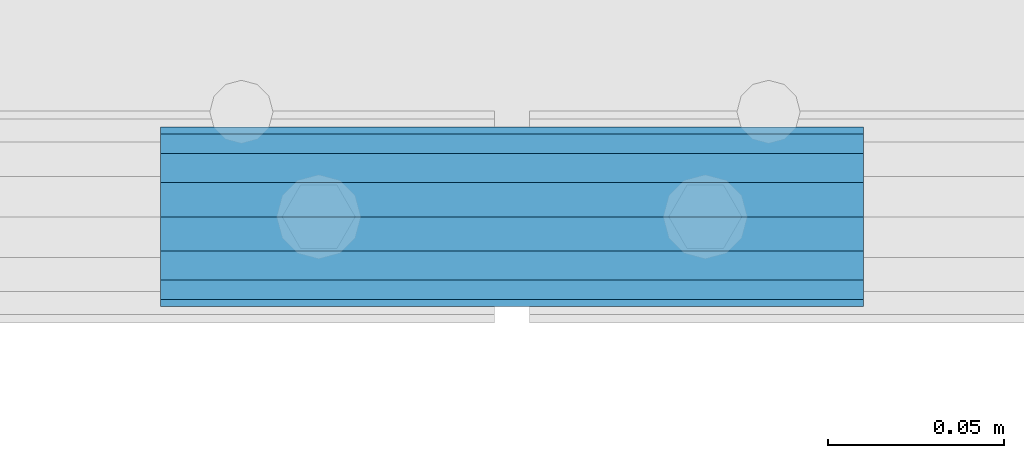
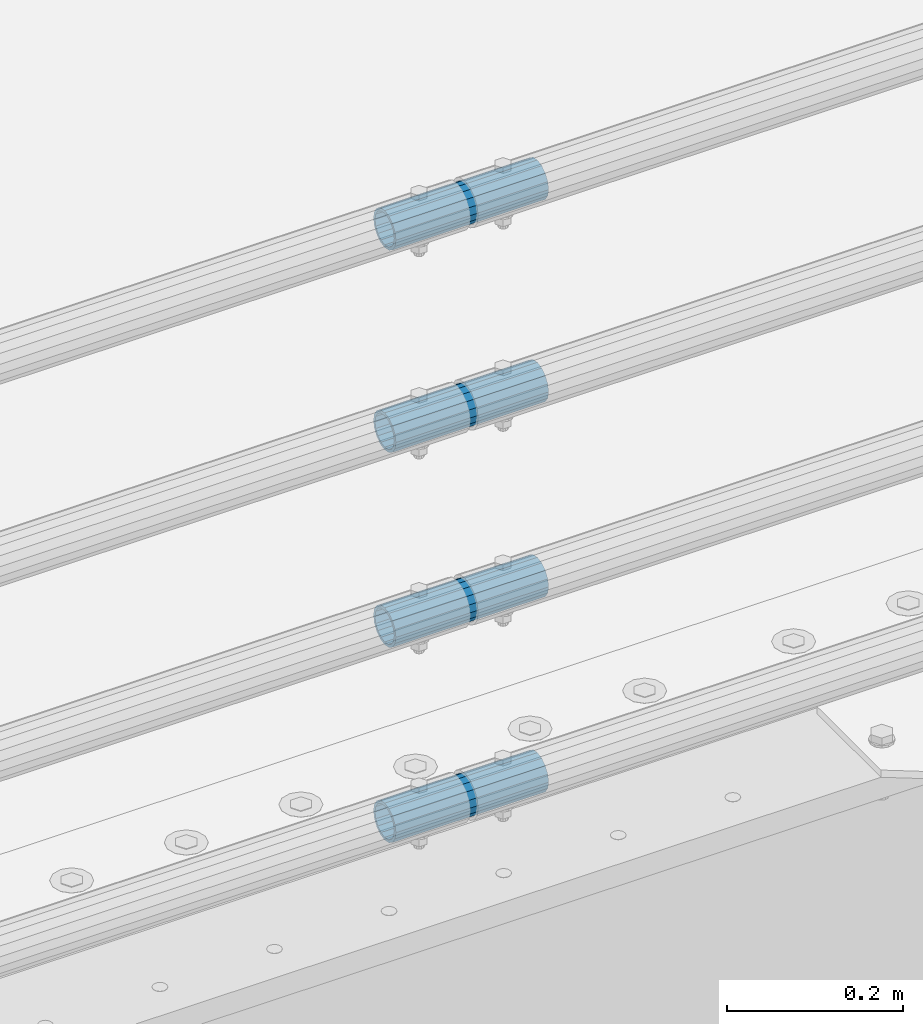
# One storey, part 143 of 257: 4 beams.
"""IFC2X3 building model written with IfcOpenShell, lengths in millimetres."""

from ifc_helpers import new_model, si_unit, frame, origin_with_axes, place, context, subcontext, project, spatial, faceted_brep, material, type_object, element, save


model = new_model("IFC2X3")

# Units and contexts
model_context = context("Model", 3, precision=1e-05, world=origin_with_axes())
body_context = subcontext(model_context, "Body", "Model", "MODEL_VIEW")
ifc_project = project(units=[si_unit("LENGTHUNIT", "METRE", prefix="MILLI"), si_unit("AREAUNIT", "SQUARE_METRE"), si_unit("VOLUMEUNIT", "CUBIC_METRE"), si_unit("MASSUNIT", "GRAM", prefix="KILO"), si_unit("TIMEUNIT", "SECOND"), si_unit("PLANEANGLEUNIT", "RADIAN"), si_unit("SOLIDANGLEUNIT", "STERADIAN"), si_unit("THERMODYNAMICTEMPERATUREUNIT", "DEGREE_CELSIUS"), si_unit("LUMINOUSINTENSITYUNIT", "LUMEN")], contexts=[model_context])

# Site, building, storey
site_placement = place(None, origin_with_axes())
site = spatial("IfcSite", under=ifc_project, at=site_placement, CompositionType="ELEMENT")
building_placement = place(site_placement, origin_with_axes())
building = spatial("IfcBuilding", under=site, at=building_placement, Name="Standard", CompositionType="ELEMENT")
storey_placement = place(building_placement, origin_with_axes())
storey = spatial("IfcBuildingStorey", under=building, at=storey_placement, Name="Undefined", CompositionType="ELEMENT", Elevation=0.0)

# Beams
ifc_material = material()
beam_type = type_object("IfcBeamType", PredefinedType="NOTDEFINED")
beam_1_placement = place(storey_placement, frame((56476.9975029999, -129.849999999603, 149.849999999725), z_axis=(0.0, 0.0, 1.0), x_axis=(1.0, 0.0, 0.0)))
element("IfcBeam", 1, at=beam_1_placement, inside=storey, type_object=beam_type, material=ifc_material, context=body_context, shape_type="Brep", body=[
    faceted_brep([(0.0, -21.8999999999996, 0.0), (0.0, -20.232961761998, 8.38076716879547), (200.0, -20.232961761998, 8.38076716879547), (200.0, -21.8999999999996, 0.0), (0.0, -15.4856385079856, 15.4856385079854), (200.0, -15.4856385079856, 15.4856385079854), (0.0, -8.3807671687955, 20.2329617619972), (200.0, -8.3807671687955, 20.2329617619972), (0.0, 0.0, 21.9), (200.0, 0.0, 21.9), (0.0, 8.3807671687955, 20.2329617619972), (200.0, 8.3807671687955, 20.2329617619972), (0.0, 15.4856385079856, 15.4856385079854), (200.0, 15.4856385079856, 15.4856385079854), (0.0, 20.232961761998, 8.38076716879547), (200.0, 20.232961761998, 8.38076716879547), (0.0, 21.8999999999996, 0.0), (200.0, 21.8999999999996, 0.0), (0.0, 20.232961761998, -8.38076716879547), (200.0, 20.232961761998, -8.38076716879547), (0.0, 15.4856385079856, -15.4856385079854), (200.0, 15.4856385079856, -15.4856385079854), (0.0, 8.3807671687955, -20.2329617619972), (200.0, 8.3807671687955, -20.2329617619972), (0.0, 0.0, -21.9), (200.0, 0.0, -21.9), (0.0, -8.3807671687955, -20.2329617619972), (200.0, -8.3807671687955, -20.2329617619972), (0.0, -15.4856385079856, -15.4856385079854), (200.0, -15.4856385079856, -15.4856385079854), (0.0, -20.232961761998, -8.38076716879547), (200.0, -20.232961761998, -8.38076716879547), (0.0, -25.5, 0.0), (0.0, -23.5589280790373, -9.7584275253098), (200.0, -23.5589280790373, -9.7584275253098), (200.0, -25.5, 0.0), (0.0, -18.0312229202573, -18.031222920257), (200.0, -18.0312229202573, -18.031222920257), (0.0, -9.75842752531025, -23.5589280790378), (200.0, -9.75842752531025, -23.5589280790378), (0.0, 0.0, -25.5), (200.0, 0.0, -25.5), (0.0, 9.75842752531025, -23.5589280790378), (200.0, 9.75842752531025, -23.5589280790378), (0.0, 18.0312229202573, -18.031222920257), (200.0, 18.0312229202573, -18.031222920257), (0.0, 23.5589280790373, -9.7584275253098), (200.0, 23.5589280790373, -9.7584275253098), (0.0, 25.5, 0.0), (200.0, 25.5, 0.0), (0.0, 23.5589280790373, 9.7584275253098), (200.0, 23.5589280790373, 9.7584275253098), (0.0, 18.0312229202573, 18.031222920257), (200.0, 18.0312229202573, 18.031222920257), (0.0, 9.75842752531025, 23.5589280790378), (200.0, 9.75842752531025, 23.5589280790378), (0.0, 0.0, 25.5), (200.0, 0.0, 25.5), (0.0, -9.75842752531025, 23.5589280790378), (200.0, -9.75842752531025, 23.5589280790378), (0.0, -18.0312229202573, 18.031222920257), (200.0, -18.0312229202573, 18.031222920257), (0.0, -23.5589280790373, 9.7584275253098), (200.0, -23.5589280790373, 9.7584275253098)], [[[0, 1, 2, 3]], [[1, 4, 5, 2]], [[4, 6, 7, 5]], [[6, 8, 9, 7]], [[8, 10, 11, 9]], [[10, 12, 13, 11]], [[12, 14, 15, 13]], [[14, 16, 17, 15]], [[16, 18, 19, 17]], [[18, 20, 21, 19]], [[20, 22, 23, 21]], [[22, 24, 25, 23]], [[24, 26, 27, 25]], [[26, 28, 29, 27]], [[28, 30, 31, 29]], [[30, 0, 3, 31]], [[32, 33, 34, 35]], [[33, 36, 37, 34]], [[36, 38, 39, 37]], [[38, 40, 41, 39]], [[40, 42, 43, 41]], [[42, 44, 45, 43]], [[44, 46, 47, 45]], [[46, 48, 49, 47]], [[48, 50, 51, 49]], [[50, 52, 53, 51]], [[52, 54, 55, 53]], [[54, 56, 57, 55]], [[56, 58, 59, 57]], [[58, 60, 61, 59]], [[60, 62, 63, 61]], [[62, 32, 35, 63]], [[37, 39, 41, 43, 45, 47, 49, 51, 53, 55, 57, 59, 61, 63, 35, 34], [5, 7, 9, 11, 13, 15, 17, 19, 21, 23, 25, 27, 29, 31, 3, 2]], [[62, 60, 58, 56, 54, 52, 50, 48, 46, 44, 42, 40, 38, 36, 33, 32], [30, 28, 26, 24, 22, 20, 18, 16, 14, 12, 10, 8, 6, 4, 1, 0]]]),
])
beam_2_placement = place(storey_placement, frame((56476.9975029999, -129.849999999603, 420.149999999724), z_axis=(0.0, 0.0, 1.0), x_axis=(1.0, 0.0, 0.0)))
element("IfcBeam", 2, at=beam_2_placement, inside=storey, type_object=beam_type, material=ifc_material, context=body_context, shape_type="Brep", body=[
    faceted_brep([(0.0, -21.8999999999996, 0.0), (0.0, -20.232961761998, 8.38076716879547), (200.0, -20.232961761998, 8.38076716879547), (200.0, -21.8999999999996, 0.0), (0.0, -15.4856385079856, 15.4856385079854), (200.0, -15.4856385079856, 15.4856385079854), (0.0, -8.3807671687955, 20.2329617619972), (200.0, -8.3807671687955, 20.2329617619972), (0.0, 0.0, 21.9), (200.0, 0.0, 21.9), (0.0, 8.3807671687955, 20.2329617619972), (200.0, 8.3807671687955, 20.2329617619972), (0.0, 15.4856385079856, 15.4856385079854), (200.0, 15.4856385079856, 15.4856385079854), (0.0, 20.232961761998, 8.38076716879547), (200.0, 20.232961761998, 8.38076716879547), (0.0, 21.8999999999996, 0.0), (200.0, 21.8999999999996, 0.0), (0.0, 20.232961761998, -8.38076716879547), (200.0, 20.232961761998, -8.38076716879547), (0.0, 15.4856385079856, -15.4856385079854), (200.0, 15.4856385079856, -15.4856385079854), (0.0, 8.3807671687955, -20.2329617619972), (200.0, 8.3807671687955, -20.2329617619972), (0.0, 0.0, -21.9), (200.0, 0.0, -21.9), (0.0, -8.3807671687955, -20.2329617619972), (200.0, -8.3807671687955, -20.2329617619972), (0.0, -15.4856385079856, -15.4856385079854), (200.0, -15.4856385079856, -15.4856385079854), (0.0, -20.232961761998, -8.38076716879547), (200.0, -20.232961761998, -8.38076716879547), (0.0, -25.5, 0.0), (0.0, -23.5589280790373, -9.7584275253098), (200.0, -23.5589280790373, -9.7584275253098), (200.0, -25.5, 0.0), (0.0, -18.0312229202573, -18.031222920257), (200.0, -18.0312229202573, -18.031222920257), (0.0, -9.75842752531025, -23.5589280790378), (200.0, -9.75842752531025, -23.5589280790378), (0.0, 0.0, -25.5), (200.0, 0.0, -25.5), (0.0, 9.75842752531025, -23.5589280790378), (200.0, 9.75842752531025, -23.5589280790378), (0.0, 18.0312229202573, -18.031222920257), (200.0, 18.0312229202573, -18.031222920257), (0.0, 23.5589280790373, -9.7584275253098), (200.0, 23.5589280790373, -9.7584275253098), (0.0, 25.5, 0.0), (200.0, 25.5, 0.0), (0.0, 23.5589280790373, 9.7584275253098), (200.0, 23.5589280790373, 9.7584275253098), (0.0, 18.0312229202573, 18.031222920257), (200.0, 18.0312229202573, 18.031222920257), (0.0, 9.75842752531025, 23.5589280790378), (200.0, 9.75842752531025, 23.5589280790378), (0.0, 0.0, 25.5), (200.0, 0.0, 25.5), (0.0, -9.75842752531025, 23.5589280790378), (200.0, -9.75842752531025, 23.5589280790378), (0.0, -18.0312229202573, 18.031222920257), (200.0, -18.0312229202573, 18.031222920257), (0.0, -23.5589280790373, 9.7584275253098), (200.0, -23.5589280790373, 9.7584275253098)], [[[0, 1, 2, 3]], [[1, 4, 5, 2]], [[4, 6, 7, 5]], [[6, 8, 9, 7]], [[8, 10, 11, 9]], [[10, 12, 13, 11]], [[12, 14, 15, 13]], [[14, 16, 17, 15]], [[16, 18, 19, 17]], [[18, 20, 21, 19]], [[20, 22, 23, 21]], [[22, 24, 25, 23]], [[24, 26, 27, 25]], [[26, 28, 29, 27]], [[28, 30, 31, 29]], [[30, 0, 3, 31]], [[32, 33, 34, 35]], [[33, 36, 37, 34]], [[36, 38, 39, 37]], [[38, 40, 41, 39]], [[40, 42, 43, 41]], [[42, 44, 45, 43]], [[44, 46, 47, 45]], [[46, 48, 49, 47]], [[48, 50, 51, 49]], [[50, 52, 53, 51]], [[52, 54, 55, 53]], [[54, 56, 57, 55]], [[56, 58, 59, 57]], [[58, 60, 61, 59]], [[60, 62, 63, 61]], [[62, 32, 35, 63]], [[37, 39, 41, 43, 45, 47, 49, 51, 53, 55, 57, 59, 61, 63, 35, 34], [5, 7, 9, 11, 13, 15, 17, 19, 21, 23, 25, 27, 29, 31, 3, 2]], [[62, 60, 58, 56, 54, 52, 50, 48, 46, 44, 42, 40, 38, 36, 33, 32], [30, 28, 26, 24, 22, 20, 18, 16, 14, 12, 10, 8, 6, 4, 1, 0]]]),
])
beam_3_placement = place(storey_placement, frame((56476.9975029999, -129.849999999603, 969.849999999725), z_axis=(0.0, 0.0, 1.0), x_axis=(1.0, 0.0, 0.0)))
element("IfcBeam", 3, at=beam_3_placement, inside=storey, type_object=beam_type, material=ifc_material, context=body_context, shape_type="Brep", body=[
    faceted_brep([(0.0, -21.8999999999996, 0.0), (0.0, -20.232961761998, 8.38076716879547), (200.0, -20.232961761998, 8.38076716879547), (200.0, -21.8999999999996, 0.0), (0.0, -15.4856385079856, 15.4856385079854), (200.0, -15.4856385079856, 15.4856385079854), (0.0, -8.3807671687955, 20.2329617619972), (200.0, -8.3807671687955, 20.2329617619972), (0.0, 0.0, 21.9), (200.0, 0.0, 21.9), (0.0, 8.3807671687955, 20.2329617619972), (200.0, 8.3807671687955, 20.2329617619972), (0.0, 15.4856385079856, 15.4856385079854), (200.0, 15.4856385079856, 15.4856385079854), (0.0, 20.232961761998, 8.38076716879547), (200.0, 20.232961761998, 8.38076716879547), (0.0, 21.8999999999996, 0.0), (200.0, 21.8999999999996, 0.0), (0.0, 20.232961761998, -8.38076716879547), (200.0, 20.232961761998, -8.38076716879547), (0.0, 15.4856385079856, -15.4856385079854), (200.0, 15.4856385079856, -15.4856385079854), (0.0, 8.3807671687955, -20.2329617619972), (200.0, 8.3807671687955, -20.2329617619972), (0.0, 0.0, -21.9), (200.0, 0.0, -21.9), (0.0, -8.3807671687955, -20.2329617619972), (200.0, -8.3807671687955, -20.2329617619972), (0.0, -15.4856385079856, -15.4856385079854), (200.0, -15.4856385079856, -15.4856385079854), (0.0, -20.232961761998, -8.38076716879547), (200.0, -20.232961761998, -8.38076716879547), (0.0, -25.5, 0.0), (0.0, -23.5589280790373, -9.7584275253098), (200.0, -23.5589280790373, -9.7584275253098), (200.0, -25.5, 0.0), (0.0, -18.0312229202573, -18.031222920257), (200.0, -18.0312229202573, -18.031222920257), (0.0, -9.75842752531025, -23.5589280790378), (200.0, -9.75842752531025, -23.5589280790378), (0.0, 0.0, -25.5), (200.0, 0.0, -25.5), (0.0, 9.75842752531025, -23.5589280790378), (200.0, 9.75842752531025, -23.5589280790378), (0.0, 18.0312229202573, -18.031222920257), (200.0, 18.0312229202573, -18.031222920257), (0.0, 23.5589280790373, -9.7584275253098), (200.0, 23.5589280790373, -9.7584275253098), (0.0, 25.5, 0.0), (200.0, 25.5, 0.0), (0.0, 23.5589280790373, 9.7584275253098), (200.0, 23.5589280790373, 9.7584275253098), (0.0, 18.0312229202573, 18.031222920257), (200.0, 18.0312229202573, 18.031222920257), (0.0, 9.75842752531025, 23.5589280790378), (200.0, 9.75842752531025, 23.5589280790378), (0.0, 0.0, 25.5), (200.0, 0.0, 25.5), (0.0, -9.75842752531025, 23.5589280790378), (200.0, -9.75842752531025, 23.5589280790378), (0.0, -18.0312229202573, 18.031222920257), (200.0, -18.0312229202573, 18.031222920257), (0.0, -23.5589280790373, 9.7584275253098), (200.0, -23.5589280790373, 9.7584275253098)], [[[0, 1, 2, 3]], [[1, 4, 5, 2]], [[4, 6, 7, 5]], [[6, 8, 9, 7]], [[8, 10, 11, 9]], [[10, 12, 13, 11]], [[12, 14, 15, 13]], [[14, 16, 17, 15]], [[16, 18, 19, 17]], [[18, 20, 21, 19]], [[20, 22, 23, 21]], [[22, 24, 25, 23]], [[24, 26, 27, 25]], [[26, 28, 29, 27]], [[28, 30, 31, 29]], [[30, 0, 3, 31]], [[32, 33, 34, 35]], [[33, 36, 37, 34]], [[36, 38, 39, 37]], [[38, 40, 41, 39]], [[40, 42, 43, 41]], [[42, 44, 45, 43]], [[44, 46, 47, 45]], [[46, 48, 49, 47]], [[48, 50, 51, 49]], [[50, 52, 53, 51]], [[52, 54, 55, 53]], [[54, 56, 57, 55]], [[56, 58, 59, 57]], [[58, 60, 61, 59]], [[60, 62, 63, 61]], [[62, 32, 35, 63]], [[37, 39, 41, 43, 45, 47, 49, 51, 53, 55, 57, 59, 61, 63, 35, 34], [5, 7, 9, 11, 13, 15, 17, 19, 21, 23, 25, 27, 29, 31, 3, 2]], [[62, 60, 58, 56, 54, 52, 50, 48, 46, 44, 42, 40, 38, 36, 33, 32], [30, 28, 26, 24, 22, 20, 18, 16, 14, 12, 10, 8, 6, 4, 1, 0]]]),
])
beam_4_placement = place(storey_placement, frame((56476.9975029999, -129.849999999603, 689.849999999725), z_axis=(0.0, 0.0, 1.0), x_axis=(1.0, 0.0, 0.0)))
element("IfcBeam", 4, at=beam_4_placement, inside=storey, type_object=beam_type, material=ifc_material, context=body_context, shape_type="Brep", body=[
    faceted_brep([(0.0, -21.8999999999996, 0.0), (0.0, -20.232961761998, 8.38076716879547), (200.0, -20.232961761998, 8.38076716879547), (200.0, -21.8999999999996, 0.0), (0.0, -15.4856385079856, 15.4856385079854), (200.0, -15.4856385079856, 15.4856385079854), (0.0, -8.3807671687955, 20.2329617619972), (200.0, -8.3807671687955, 20.2329617619972), (0.0, 0.0, 21.9), (200.0, 0.0, 21.9), (0.0, 8.3807671687955, 20.2329617619972), (200.0, 8.3807671687955, 20.2329617619972), (0.0, 15.4856385079856, 15.4856385079854), (200.0, 15.4856385079856, 15.4856385079854), (0.0, 20.232961761998, 8.38076716879547), (200.0, 20.232961761998, 8.38076716879547), (0.0, 21.8999999999996, 0.0), (200.0, 21.8999999999996, 0.0), (0.0, 20.232961761998, -8.38076716879547), (200.0, 20.232961761998, -8.38076716879547), (0.0, 15.4856385079856, -15.4856385079854), (200.0, 15.4856385079856, -15.4856385079854), (0.0, 8.3807671687955, -20.2329617619972), (200.0, 8.3807671687955, -20.2329617619972), (0.0, 0.0, -21.9), (200.0, 0.0, -21.9), (0.0, -8.3807671687955, -20.2329617619972), (200.0, -8.3807671687955, -20.2329617619972), (0.0, -15.4856385079856, -15.4856385079854), (200.0, -15.4856385079856, -15.4856385079854), (0.0, -20.232961761998, -8.38076716879547), (200.0, -20.232961761998, -8.38076716879547), (0.0, -25.5, 0.0), (0.0, -23.5589280790373, -9.7584275253098), (200.0, -23.5589280790373, -9.7584275253098), (200.0, -25.5, 0.0), (0.0, -18.0312229202573, -18.031222920257), (200.0, -18.0312229202573, -18.031222920257), (0.0, -9.75842752531025, -23.5589280790378), (200.0, -9.75842752531025, -23.5589280790378), (0.0, 0.0, -25.5), (200.0, 0.0, -25.5), (0.0, 9.75842752531025, -23.5589280790378), (200.0, 9.75842752531025, -23.5589280790378), (0.0, 18.0312229202573, -18.031222920257), (200.0, 18.0312229202573, -18.031222920257), (0.0, 23.5589280790373, -9.7584275253098), (200.0, 23.5589280790373, -9.7584275253098), (0.0, 25.5, 0.0), (200.0, 25.5, 0.0), (0.0, 23.5589280790373, 9.7584275253098), (200.0, 23.5589280790373, 9.7584275253098), (0.0, 18.0312229202573, 18.031222920257), (200.0, 18.0312229202573, 18.031222920257), (0.0, 9.75842752531025, 23.5589280790378), (200.0, 9.75842752531025, 23.5589280790378), (0.0, 0.0, 25.5), (200.0, 0.0, 25.5), (0.0, -9.75842752531025, 23.5589280790378), (200.0, -9.75842752531025, 23.5589280790378), (0.0, -18.0312229202573, 18.031222920257), (200.0, -18.0312229202573, 18.031222920257), (0.0, -23.5589280790373, 9.7584275253098), (200.0, -23.5589280790373, 9.7584275253098)], [[[0, 1, 2, 3]], [[1, 4, 5, 2]], [[4, 6, 7, 5]], [[6, 8, 9, 7]], [[8, 10, 11, 9]], [[10, 12, 13, 11]], [[12, 14, 15, 13]], [[14, 16, 17, 15]], [[16, 18, 19, 17]], [[18, 20, 21, 19]], [[20, 22, 23, 21]], [[22, 24, 25, 23]], [[24, 26, 27, 25]], [[26, 28, 29, 27]], [[28, 30, 31, 29]], [[30, 0, 3, 31]], [[32, 33, 34, 35]], [[33, 36, 37, 34]], [[36, 38, 39, 37]], [[38, 40, 41, 39]], [[40, 42, 43, 41]], [[42, 44, 45, 43]], [[44, 46, 47, 45]], [[46, 48, 49, 47]], [[48, 50, 51, 49]], [[50, 52, 53, 51]], [[52, 54, 55, 53]], [[54, 56, 57, 55]], [[56, 58, 59, 57]], [[58, 60, 61, 59]], [[60, 62, 63, 61]], [[62, 32, 35, 63]], [[37, 39, 41, 43, 45, 47, 49, 51, 53, 55, 57, 59, 61, 63, 35, 34], [5, 7, 9, 11, 13, 15, 17, 19, 21, 23, 25, 27, 29, 31, 3, 2]], [[62, 60, 58, 56, 54, 52, 50, 48, 46, 44, 42, 40, 38, 36, 33, 32], [30, 28, 26, 24, 22, 20, 18, 16, 14, 12, 10, 8, 6, 4, 1, 0]]]),
])

save(model, "model.ifc")
